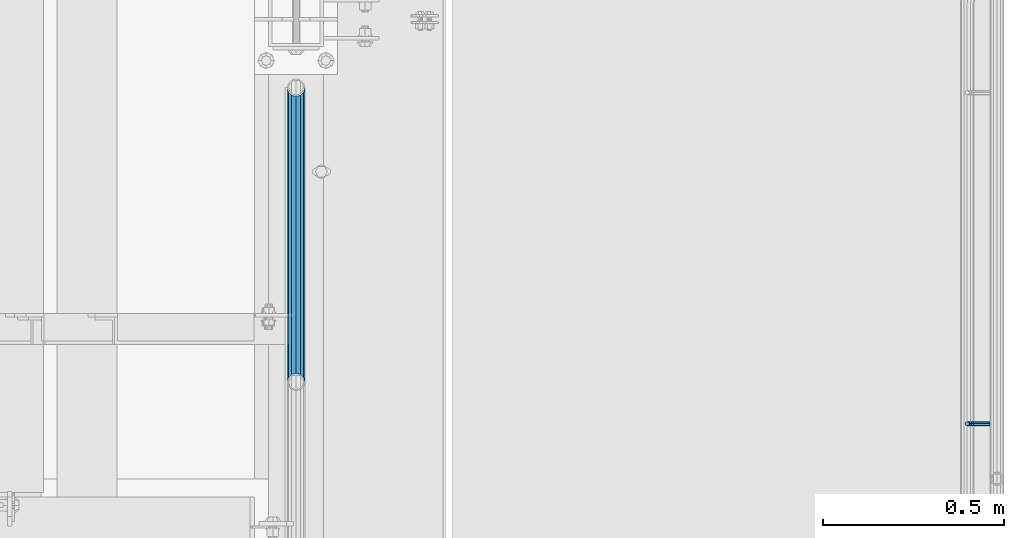
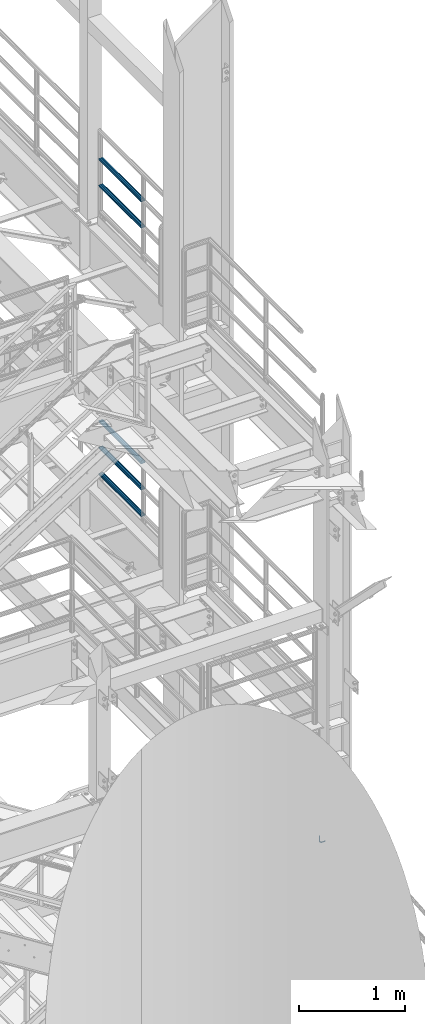
# One storey, part 1223 of 1876: 6 beams, 3 elements without a shape of their own.
"""IFC2X3 building model written with IfcOpenShell, lengths in millimetres."""

from ifc_helpers import new_model, si_unit, frame, origin_with_axes, place, context, subcontext, project, spatial, faceted_brep, material, type_object, element, aggregate, save


model = new_model("IFC2X3")

# Units and contexts
model_context = context("Model", 3, precision=1e-05, world=origin_with_axes())
body_context = subcontext(model_context, "Body", "Model", "MODEL_VIEW")
ifc_project = project(units=[si_unit("LENGTHUNIT", "METRE", prefix="MILLI"), si_unit("AREAUNIT", "SQUARE_METRE"), si_unit("VOLUMEUNIT", "CUBIC_METRE"), si_unit("MASSUNIT", "GRAM", prefix="KILO"), si_unit("TIMEUNIT", "SECOND"), si_unit("PLANEANGLEUNIT", "RADIAN"), si_unit("SOLIDANGLEUNIT", "STERADIAN"), si_unit("THERMODYNAMICTEMPERATUREUNIT", "DEGREE_CELSIUS"), si_unit("LUMINOUSINTENSITYUNIT", "LUMEN")], contexts=[model_context])

# Site, building, storey
site_placement = place(None, origin_with_axes())
site = spatial("IfcSite", under=ifc_project, at=site_placement, CompositionType="ELEMENT")
building_placement = place(site_placement, origin_with_axes())
building = spatial("IfcBuilding", under=site, at=building_placement, Name="Undefined", CompositionType="ELEMENT")
storey_placement = place(building_placement, origin_with_axes())
storey = spatial("IfcBuildingStorey", under=building, at=storey_placement, Name="Undefined", CompositionType="ELEMENT", Elevation=0.0)

# Assembly, beams
assembly_1_placement = place(storey_placement, origin_with_axes())
assembly_1 = element("IfcElementAssembly", 1, at=assembly_1_placement, inside=storey, Name="RAIL", AssemblyPlace="NOTDEFINED", PredefinedType="RIGID_FRAME")
ifc_material_1 = material()
beam_type_1 = type_object("IfcBeamType", Name="PIPE1-1/2SCH40", PredefinedType="NOTDEFINED")
beam_1_placement = place(assembly_1_placement, frame((7620.0, -3542.7031, 8620.125), z_axis=(0.0, 0.0, -1.0), x_axis=(0.0, 1.0, 0.0)))
beam_1 = element("IfcBeam", 2, at=beam_1_placement, type_object=beam_type_1, material=ifc_material_1, Name="RAIL", ObjectType="PIPE1-1/2SCH40", context=body_context, shape_type="Brep", body=[
    faceted_brep([(0.0, 24.1299999999992, 0.0), (12.0650000000064, 20.8971929933177, -12.0649999999987), (12.0650000000064, 20.8971929933177, 12.0649999999987), (12.0650000000064, -20.8971929933177, 12.0649999999987), (12.0650000000064, -20.8971929933177, -12.0649999999987), (0.0, -24.1299999999992, 0.0), (20.8971929933249, -12.0650000000005, 20.8971929933177), (20.8971929933249, -12.0650000000005, 15.8661214311796), (15.2545715621445, -17.7076214311801, 10.2235000000001), (12.5151929933249, -20.4470000000001, 0.0), (15.2545715621445, -17.7076214311801, -10.2235000000001), (20.8971929933249, -12.0650000000005, -15.8661214311796), (20.8971929933249, -12.0650000000005, -20.8971929933177), (24.1300000000063, 0.0, -20.4470000000001), (24.1300000000063, 0.0, -24.130000000001), (21.3906214311868, -10.2235000000001, -17.7076214311819), (21.3906214311868, 10.2235000000001, -17.7076214311819), (20.8971929933249, 12.0650000000005, -15.8661214311796), (20.8971929933249, 12.0650000000005, -20.8971929933177), (15.2545715621445, 17.7076214311801, -10.2235000000001), (12.5151929933249, 20.4470000000001, 0.0), (15.2545715621445, 17.7076214311801, 10.2235000000001), (20.8971929933249, 12.0650000000005, 15.8661214311796), (20.8971929933249, 12.0650000000005, 20.8971929933177), (21.3906214311868, 10.2235000000001, 17.7076214311819), (24.1300000000064, 0.0, 20.4470000000001), (24.1300000000064, 0.0, 24.130000000001), (21.3906214311868, -10.2235000000001, 17.7076214311819), (813.396900000002, 24.1300000000001, 0.0), (801.331900000001, 20.8971929933186, -12.0649999999987), (792.499707006684, 12.0649999999996, -20.8971929933177), (813.396900000002, -24.1300000000319, 0.0), (801.331900000001, -20.8971929933186, -12.0649999999987), (801.331900000001, -20.8971929933186, 12.0649999999987), (792.499707006684, -12.0649999999996, 20.8971929933177), (792.499707006684, -12.0649999999996, -20.8971929933177), (789.266900000001, 0.0, -24.130000000001), (792.00627856883, 10.2235000000001, -17.7076214311819), (789.266900000001, 0.0, -20.4470000000001), (792.499707006684, 12.0649999999678, -15.8661214312124), (792.499707006684, -12.0650000000314, -15.8661214311469), (792.006278568813, -10.2235000000001, -17.7076214311819), (798.142328437831, -17.7076214311801, -10.2235000000001), (800.881707006651, -20.4470000000001, 0.0), (798.142328437831, -17.7076214311801, 10.2235000000001), (792.499707006684, -12.0650000000314, 15.8661214311469), (792.006278568813, -10.2235000000001, 17.7076214311819), (789.266900000001, -9.09494701772928e-13, 20.4470000000001), (789.266900000001, -9.09494701772928e-13, 24.130000000001), (792.499707006684, 12.0649999999996, 20.8971929933177), (801.331900000001, 20.8971929933186, 12.0649999999987), (792.499707006684, 12.0649999999678, 15.8661214312124), (798.142328437896, 17.7076214311801, 10.2235000000001), (800.881707006714, 20.4470000000001, 0.0), (798.142328437896, 17.7076214311801, -10.2235000000001), (792.00627856883, 10.2235000000001, 17.7076214311819)], [[[0, 1, 2]], [[3, 4, 5]], [[6, 7, 8, 9, 10, 11, 12, 4, 3]], [[13, 14, 12, 11, 15]], [[16, 17, 18, 14, 13]], [[2, 1, 18, 17, 19, 20, 21, 22, 23]], [[23, 22, 24, 25, 26]], [[26, 25, 27, 7, 6]], [[1, 0, 28, 29]], [[18, 1, 29, 30]], [[31, 32, 33]], [[6, 3, 33, 34]], [[3, 5, 31, 33]], [[5, 4, 32, 31]], [[4, 12, 35, 32]], [[12, 14, 36, 35]], [[14, 18, 30, 36]], [[37, 38, 36, 30, 39]], [[40, 35, 36, 38, 41]], [[33, 32, 35, 40, 42, 43, 44, 45, 34]], [[34, 45, 46, 47, 48]], [[26, 6, 34, 48]], [[2, 23, 49, 50]], [[23, 26, 48, 49]], [[0, 2, 50, 28]], [[28, 50, 29]], [[49, 51, 52, 53, 54, 39, 30, 29, 50]], [[48, 47, 55, 51, 49]], [[25, 24, 55, 47]], [[55, 24, 22, 21, 52, 51]], [[21, 20, 53, 52]], [[20, 19, 54, 53]], [[19, 17, 16, 37, 39, 54]], [[16, 13, 38, 37]], [[13, 15, 41, 38]], [[41, 15, 11, 10, 42, 40]], [[10, 9, 43, 42]], [[9, 8, 44, 43]], [[8, 7, 27, 46, 45, 44]], [[27, 25, 47, 46]]]),
])
beam_2_placement = place(assembly_1_placement, frame((7620.0, -3542.7031, 8924.925), z_axis=(0.0, 0.0, -1.0), x_axis=(0.0, 1.0, 0.0)))
beam_2 = element("IfcBeam", 3, at=beam_2_placement, type_object=beam_type_1, material=ifc_material_1, Name="RAIL", ObjectType="PIPE1-1/2SCH40", context=body_context, shape_type="Brep", body=[
    faceted_brep([(0.0, 24.1299999999992, 0.0), (12.0650000000064, 20.8971929933177, -12.0649999999987), (12.0650000000064, 20.8971929933177, 12.0649999999987), (12.0650000000064, -20.8971929933177, 12.0649999999987), (12.0650000000064, -20.8971929933177, -12.0649999999987), (0.0, -24.1299999999992, 0.0), (20.8971929933249, -12.0650000000005, 20.8971929933177), (20.8971929933249, -12.0650000000005, 15.8661214311796), (15.2545715621445, -17.7076214311801, 10.2235000000001), (12.5151929933249, -20.4470000000001, 0.0), (15.2545715621445, -17.7076214311801, -10.2235000000001), (20.8971929933249, -12.0650000000005, -15.8661214311796), (20.8971929933249, -12.0650000000005, -20.8971929933177), (24.1300000000063, 0.0, -20.4470000000001), (24.1300000000063, 0.0, -24.130000000001), (21.3906214311868, -10.2235000000001, -17.7076214311819), (21.3906214311868, 10.2235000000001, -17.7076214311819), (20.8971929933249, 12.0650000000005, -15.8661214311796), (20.8971929933249, 12.0650000000005, -20.8971929933177), (15.2545715621445, 17.7076214311801, -10.2235000000001), (12.5151929933249, 20.4470000000001, 0.0), (15.2545715621445, 17.7076214311801, 10.2235000000001), (20.8971929933249, 12.0650000000005, 15.8661214311796), (20.8971929933249, 12.0650000000005, 20.8971929933177), (21.3906214311868, 10.2235000000001, 17.7076214311819), (24.1300000000064, 0.0, 20.4470000000001), (24.1300000000064, 0.0, 24.130000000001), (21.3906214311868, -10.2235000000001, 17.7076214311819), (813.396900000002, 24.1300000000001, 0.0), (801.331900000001, 20.8971929933186, -12.0649999999987), (792.499707006684, 12.0649999999996, -20.8971929933177), (813.396900000002, -24.1300000000319, 0.0), (801.331900000001, -20.8971929933186, -12.0649999999987), (801.331900000001, -20.8971929933186, 12.0649999999987), (792.499707006684, -12.0649999999996, 20.8971929933177), (792.499707006684, -12.0649999999996, -20.8971929933177), (789.266900000001, 0.0, -24.130000000001), (792.00627856883, 10.2235000000001, -17.7076214311819), (789.266900000001, 0.0, -20.4470000000001), (792.499707006684, 12.0649999999678, -15.8661214312124), (792.499707006684, -12.0650000000314, -15.8661214311469), (792.006278568813, -10.2235000000001, -17.7076214311819), (798.142328437831, -17.7076214311801, -10.2235000000001), (800.881707006651, -20.4470000000001, 0.0), (798.142328437831, -17.7076214311801, 10.2235000000001), (792.499707006684, -12.0650000000314, 15.8661214311469), (792.006278568813, -10.2235000000001, 17.7076214311819), (789.266900000001, -9.09494701772928e-13, 20.4470000000001), (789.266900000001, -9.09494701772928e-13, 24.130000000001), (792.499707006684, 12.0649999999996, 20.8971929933177), (801.331900000001, 20.8971929933186, 12.0649999999987), (792.499707006684, 12.0649999999678, 15.8661214312124), (798.142328437896, 17.7076214311801, 10.2235000000001), (800.881707006714, 20.4470000000001, 0.0), (798.142328437896, 17.7076214311801, -10.2235000000001), (792.00627856883, 10.2235000000001, 17.7076214311819)], [[[0, 1, 2]], [[3, 4, 5]], [[6, 7, 8, 9, 10, 11, 12, 4, 3]], [[13, 14, 12, 11, 15]], [[16, 17, 18, 14, 13]], [[2, 1, 18, 17, 19, 20, 21, 22, 23]], [[23, 22, 24, 25, 26]], [[26, 25, 27, 7, 6]], [[1, 0, 28, 29]], [[18, 1, 29, 30]], [[31, 32, 33]], [[6, 3, 33, 34]], [[3, 5, 31, 33]], [[5, 4, 32, 31]], [[4, 12, 35, 32]], [[12, 14, 36, 35]], [[14, 18, 30, 36]], [[37, 38, 36, 30, 39]], [[40, 35, 36, 38, 41]], [[33, 32, 35, 40, 42, 43, 44, 45, 34]], [[34, 45, 46, 47, 48]], [[26, 6, 34, 48]], [[2, 23, 49, 50]], [[23, 26, 48, 49]], [[0, 2, 50, 28]], [[28, 50, 29]], [[49, 51, 52, 53, 54, 39, 30, 29, 50]], [[48, 47, 55, 51, 49]], [[25, 24, 55, 47]], [[55, 24, 22, 21, 52, 51]], [[21, 20, 53, 52]], [[20, 19, 54, 53]], [[19, 17, 16, 37, 39, 54]], [[16, 13, 38, 37]], [[13, 15, 41, 38]], [[41, 15, 11, 10, 42, 40]], [[10, 9, 43, 42]], [[9, 8, 44, 43]], [[8, 7, 27, 46, 45, 44]], [[27, 25, 47, 46]]]),
])
aggregate(assembly_1, [beam_1, beam_2])

assembly_2_placement = place(storey_placement, origin_with_axes())
assembly_2 = element("IfcElementAssembly", 4, at=assembly_2_placement, inside=storey, Name="RAIL", AssemblyPlace="NOTDEFINED", PredefinedType="RIGID_FRAME")
beam_3_placement = place(assembly_2_placement, frame((7620.00000000001, -2729.3062, 5292.725), z_axis=(0.0, 0.0, 1.0), x_axis=(0.0, -1.0, 0.0)))
beam_3 = element("IfcBeam", 5, at=beam_3_placement, type_object=beam_type_1, material=ifc_material_1, Name="RAIL", ObjectType="PIPE1-1/2SCH40", context=body_context, shape_type="Brep", body=[
    faceted_brep([(792.499707006684, -12.0649999999996, 20.8971929933177), (792.499707006684, -12.0650000000314, 15.8661214311469), (792.006278568813, -10.2235000000001, 17.7076214311819), (789.266900000001, -9.09494701772928e-13, 20.4470000000001), (789.266900000001, -9.09494701772928e-13, 24.130000000001), (792.00627856883, 10.2235000000001, 17.7076214311819), (792.499707006684, 12.0649999999678, 15.8661214312124), (792.499707006684, 12.0649999999996, 20.8971929933177), (813.396900000002, 24.1300000000001, 0.0), (801.331900000001, 20.8971929933186, 12.0649999999987), (801.331900000001, 20.8971929933186, -12.0649999999987), (798.142328437896, 17.7076214311801, 10.2235000000001), (800.881707006714, 20.4470000000001, 0.0), (798.142328437896, 17.7076214311801, -10.2235000000001), (792.499707006684, 12.0649999999678, -15.8661214312124), (792.499707006684, 12.0649999999996, -20.8971929933177), (792.00627856883, 10.2235000000001, -17.7076214311819), (789.266900000001, 0.0, -20.4470000000001), (789.266900000001, 0.0, -24.130000000001), (792.499707006684, -12.0650000000314, -15.8661214311469), (792.499707006684, -12.0649999999996, -20.8971929933177), (792.006278568813, -10.2235000000001, -17.7076214311819), (813.396900000002, -24.1300000000319, 0.0), (801.331900000001, -20.8971929933186, -12.0649999999987), (801.331900000001, -20.8971929933186, 12.0649999999987), (798.142328437831, -17.7076214311801, -10.2235000000001), (800.881707006651, -20.4470000000001, 0.0), (798.142328437831, -17.7076214311801, 10.2235000000001), (12.0650000000064, -20.8971929933177, -12.0649999999987), (20.8971929933249, -12.0650000000005, -20.8971929933177), (0.0, 24.1299999999992, 0.0), (12.0650000000064, 20.8971929933177, -12.0649999999987), (12.0650000000064, 20.8971929933177, 12.0649999999987), (20.8971929933249, 12.0650000000005, 20.8971929933177), (24.1300000000064, 0.0, 24.130000000001), (20.8971929933249, 12.0650000000005, -20.8971929933177), (24.1300000000063, 0.0, -24.130000000001), (24.1300000000063, 0.0, -20.4470000000001), (20.8971929933249, -12.0650000000005, -15.8661214311796), (21.3906214311868, -10.2235000000001, -17.7076214311819), (21.3906214311868, 10.2235000000001, -17.7076214311819), (20.8971929933249, 12.0650000000005, -15.8661214311796), (15.2545715621445, 17.7076214311801, -10.2235000000001), (12.5151929933249, 20.4470000000001, 0.0), (15.2545715621445, 17.7076214311801, 10.2235000000001), (20.8971929933249, 12.0650000000005, 15.8661214311796), (21.3906214311868, 10.2235000000001, 17.7076214311819), (24.1300000000064, 0.0, 20.4470000000001), (21.3906214311868, -10.2235000000001, 17.7076214311819), (20.8971929933249, -12.0650000000005, 15.8661214311796), (20.8971929933249, -12.0650000000005, 20.8971929933177), (12.0650000000064, -20.8971929933177, 12.0649999999987), (0.0, -24.1299999999992, 0.0), (15.2545715621445, -17.7076214311801, 10.2235000000001), (12.5151929933249, -20.4470000000001, 0.0), (15.2545715621445, -17.7076214311801, -10.2235000000001)], [[[0, 1, 2, 3, 4]], [[4, 3, 5, 6, 7]], [[8, 9, 10]], [[7, 6, 11, 12, 13, 14, 15, 10, 9]], [[16, 17, 18, 15, 14]], [[19, 20, 18, 17, 21]], [[22, 23, 24]], [[24, 23, 20, 19, 25, 26, 27, 1, 0]], [[28, 29, 20, 23]], [[30, 31, 32]], [[33, 34, 4, 7]], [[32, 33, 7, 9]], [[30, 32, 9, 8]], [[31, 30, 8, 10]], [[35, 31, 10, 15]], [[36, 35, 15, 18]], [[29, 36, 18, 20]], [[37, 36, 29, 38, 39]], [[40, 41, 35, 36, 37]], [[32, 31, 35, 41, 42, 43, 44, 45, 33]], [[33, 45, 46, 47, 34]], [[34, 47, 48, 49, 50]], [[34, 50, 0, 4]], [[50, 51, 24, 0]], [[51, 52, 22, 24]], [[52, 28, 23, 22]], [[51, 28, 52]], [[50, 49, 53, 54, 55, 38, 29, 28, 51]], [[55, 54, 26, 25]], [[21, 39, 38, 55, 25, 19]], [[37, 39, 21, 17]], [[40, 37, 17, 16]], [[42, 41, 40, 16, 14, 13]], [[43, 42, 13, 12]], [[44, 43, 12, 11]], [[5, 46, 45, 44, 11, 6]], [[47, 46, 5, 3]], [[48, 47, 3, 2]], [[53, 49, 48, 2, 1, 27]], [[54, 53, 27, 26]]]),
])
beam_4_placement = place(assembly_2_placement, frame((7620.0, -3542.70310000001, 5597.525), z_axis=(0.0, 0.0, -1.0), x_axis=(0.0, 1.0, 0.0)))
beam_4 = element("IfcBeam", 6, at=beam_4_placement, type_object=beam_type_1, material=ifc_material_1, Name="RAIL", ObjectType="PIPE1-1/2SCH40", context=body_context, shape_type="Brep", body=[
    faceted_brep([(0.0, 24.1299999999992, 0.0), (12.0650000000064, 20.8971929933177, -12.0649999999987), (12.0650000000064, 20.8971929933177, 12.0649999999987), (12.0650000000064, -20.8971929933177, 12.0649999999987), (12.0650000000064, -20.8971929933177, -12.0649999999987), (0.0, -24.1299999999992, 0.0), (20.8971929933249, -12.0650000000005, 20.8971929933177), (20.8971929933249, -12.0650000000005, 15.8661214311796), (15.2545715621445, -17.7076214311801, 10.2235000000001), (12.5151929933249, -20.4470000000001, 0.0), (15.2545715621445, -17.7076214311801, -10.2235000000001), (20.8971929933249, -12.0650000000005, -15.8661214311796), (20.8971929933249, -12.0650000000005, -20.8971929933177), (24.1300000000063, 0.0, -20.4470000000001), (24.1300000000063, 0.0, -24.130000000001), (21.3906214311868, -10.2235000000001, -17.7076214311819), (21.3906214311868, 10.2235000000001, -17.7076214311819), (20.8971929933249, 12.0650000000005, -15.8661214311796), (20.8971929933249, 12.0650000000005, -20.8971929933177), (15.2545715621445, 17.7076214311801, -10.2235000000001), (12.5151929933249, 20.4470000000001, 0.0), (15.2545715621445, 17.7076214311801, 10.2235000000001), (20.8971929933249, 12.0650000000005, 15.8661214311796), (20.8971929933249, 12.0650000000005, 20.8971929933177), (21.3906214311868, 10.2235000000001, 17.7076214311819), (24.1300000000064, 0.0, 20.4470000000001), (24.1300000000064, 0.0, 24.130000000001), (21.3906214311868, -10.2235000000001, 17.7076214311819), (813.396900000002, 24.1300000000001, 0.0), (801.331900000001, 20.8971929933186, -12.0649999999987), (792.499707006684, 12.0649999999996, -20.8971929933177), (813.396900000002, -24.1300000000319, 0.0), (801.331900000001, -20.8971929933186, -12.0649999999987), (801.331900000001, -20.8971929933186, 12.0649999999987), (792.499707006684, -12.0649999999996, 20.8971929933177), (792.499707006684, -12.0649999999996, -20.8971929933177), (789.266900000001, 0.0, -24.130000000001), (792.00627856883, 10.2235000000001, -17.7076214311819), (789.266900000001, 0.0, -20.4470000000001), (792.499707006684, 12.0649999999678, -15.8661214312124), (792.499707006684, -12.0650000000314, -15.8661214311469), (792.006278568813, -10.2235000000001, -17.7076214311819), (798.142328437831, -17.7076214311801, -10.2235000000001), (800.881707006651, -20.4470000000001, 0.0), (798.142328437831, -17.7076214311801, 10.2235000000001), (792.499707006684, -12.0650000000314, 15.8661214311469), (792.006278568813, -10.2235000000001, 17.7076214311819), (789.266900000001, -9.09494701772928e-13, 20.4470000000001), (789.266900000001, -9.09494701772928e-13, 24.130000000001), (792.499707006684, 12.0649999999996, 20.8971929933177), (801.331900000001, 20.8971929933186, 12.0649999999987), (792.499707006684, 12.0649999999678, 15.8661214312124), (798.142328437896, 17.7076214311801, 10.2235000000001), (800.881707006714, 20.4470000000001, 0.0), (798.142328437896, 17.7076214311801, -10.2235000000001), (792.00627856883, 10.2235000000001, 17.7076214311819)], [[[0, 1, 2]], [[3, 4, 5]], [[6, 7, 8, 9, 10, 11, 12, 4, 3]], [[13, 14, 12, 11, 15]], [[16, 17, 18, 14, 13]], [[2, 1, 18, 17, 19, 20, 21, 22, 23]], [[23, 22, 24, 25, 26]], [[26, 25, 27, 7, 6]], [[1, 0, 28, 29]], [[18, 1, 29, 30]], [[31, 32, 33]], [[6, 3, 33, 34]], [[3, 5, 31, 33]], [[5, 4, 32, 31]], [[4, 12, 35, 32]], [[12, 14, 36, 35]], [[14, 18, 30, 36]], [[37, 38, 36, 30, 39]], [[40, 35, 36, 38, 41]], [[33, 32, 35, 40, 42, 43, 44, 45, 34]], [[34, 45, 46, 47, 48]], [[26, 6, 34, 48]], [[2, 23, 49, 50]], [[23, 26, 48, 49]], [[0, 2, 50, 28]], [[28, 50, 29]], [[49, 51, 52, 53, 54, 39, 30, 29, 50]], [[48, 47, 55, 51, 49]], [[25, 24, 55, 47]], [[55, 24, 22, 21, 52, 51]], [[21, 20, 53, 52]], [[20, 19, 54, 53]], [[19, 17, 16, 37, 39, 54]], [[16, 13, 38, 37]], [[13, 15, 41, 38]], [[41, 15, 11, 10, 42, 40]], [[10, 9, 43, 42]], [[9, 8, 44, 43]], [[8, 7, 27, 46, 45, 44]], [[27, 25, 47, 46]]]),
])
beam_5_placement = place(assembly_2_placement, frame((7620.0, -3542.70310000001, 5902.325), z_axis=(0.0, 0.0, -1.0), x_axis=(0.0, 1.0, 0.0)))
beam_5 = element("IfcBeam", 7, at=beam_5_placement, type_object=beam_type_1, material=ifc_material_1, Name="RAIL", ObjectType="PIPE1-1/2SCH40", context=body_context, shape_type="Brep", body=[
    faceted_brep([(0.0, 24.1299999999992, 0.0), (12.0650000000064, 20.8971929933177, -12.0649999999987), (12.0650000000064, 20.8971929933177, 12.0649999999987), (12.0650000000064, -20.8971929933177, 12.0649999999987), (12.0650000000064, -20.8971929933177, -12.0649999999987), (0.0, -24.1299999999992, 0.0), (20.8971929933249, -12.0650000000005, 20.8971929933177), (20.8971929933249, -12.0650000000005, 15.8661214311796), (15.2545715621445, -17.7076214311801, 10.2235000000001), (12.5151929933249, -20.4470000000001, 0.0), (15.2545715621445, -17.7076214311801, -10.2235000000001), (20.8971929933249, -12.0650000000005, -15.8661214311796), (20.8971929933249, -12.0650000000005, -20.8971929933177), (24.1300000000063, 0.0, -20.4470000000001), (24.1300000000063, 0.0, -24.130000000001), (21.3906214311868, -10.2235000000001, -17.7076214311819), (21.3906214311868, 10.2235000000001, -17.7076214311819), (20.8971929933249, 12.0650000000005, -15.8661214311796), (20.8971929933249, 12.0650000000005, -20.8971929933177), (15.2545715621445, 17.7076214311801, -10.2235000000001), (12.5151929933249, 20.4470000000001, 0.0), (15.2545715621445, 17.7076214311801, 10.2235000000001), (20.8971929933249, 12.0650000000005, 15.8661214311796), (20.8971929933249, 12.0650000000005, 20.8971929933177), (21.3906214311868, 10.2235000000001, 17.7076214311819), (24.1300000000064, 0.0, 20.4470000000001), (24.1300000000064, 0.0, 24.130000000001), (21.3906214311868, -10.2235000000001, 17.7076214311819), (813.396900000002, 24.1300000000001, 0.0), (801.331900000001, 20.8971929933186, -12.0649999999987), (792.499707006684, 12.0649999999996, -20.8971929933177), (813.396900000002, -24.1300000000319, 0.0), (801.331900000001, -20.8971929933186, -12.0649999999987), (801.331900000001, -20.8971929933186, 12.0649999999987), (792.499707006684, -12.0649999999996, 20.8971929933177), (792.499707006684, -12.0649999999996, -20.8971929933177), (789.266900000001, 0.0, -24.130000000001), (792.00627856883, 10.2235000000001, -17.7076214311819), (789.266900000001, 0.0, -20.4470000000001), (792.499707006684, 12.0649999999678, -15.8661214312124), (792.499707006684, -12.0650000000314, -15.8661214311469), (792.006278568813, -10.2235000000001, -17.7076214311819), (798.142328437831, -17.7076214311801, -10.2235000000001), (800.881707006651, -20.4470000000001, 0.0), (798.142328437831, -17.7076214311801, 10.2235000000001), (792.499707006684, -12.0650000000314, 15.8661214311469), (792.006278568813, -10.2235000000001, 17.7076214311819), (789.266900000001, -9.09494701772928e-13, 20.4470000000001), (789.266900000001, -9.09494701772928e-13, 24.130000000001), (792.499707006684, 12.0649999999996, 20.8971929933177), (801.331900000001, 20.8971929933186, 12.0649999999987), (792.499707006684, 12.0649999999678, 15.8661214312124), (798.142328437896, 17.7076214311801, 10.2235000000001), (800.881707006714, 20.4470000000001, 0.0), (798.142328437896, 17.7076214311801, -10.2235000000001), (792.00627856883, 10.2235000000001, 17.7076214311819)], [[[0, 1, 2]], [[3, 4, 5]], [[6, 7, 8, 9, 10, 11, 12, 4, 3]], [[13, 14, 12, 11, 15]], [[16, 17, 18, 14, 13]], [[2, 1, 18, 17, 19, 20, 21, 22, 23]], [[23, 22, 24, 25, 26]], [[26, 25, 27, 7, 6]], [[1, 0, 28, 29]], [[18, 1, 29, 30]], [[31, 32, 33]], [[6, 3, 33, 34]], [[3, 5, 31, 33]], [[5, 4, 32, 31]], [[4, 12, 35, 32]], [[12, 14, 36, 35]], [[14, 18, 30, 36]], [[37, 38, 36, 30, 39]], [[40, 35, 36, 38, 41]], [[33, 32, 35, 40, 42, 43, 44, 45, 34]], [[34, 45, 46, 47, 48]], [[26, 6, 34, 48]], [[2, 23, 49, 50]], [[23, 26, 48, 49]], [[0, 2, 50, 28]], [[28, 50, 29]], [[49, 51, 52, 53, 54, 39, 30, 29, 50]], [[48, 47, 55, 51, 49]], [[25, 24, 55, 47]], [[55, 24, 22, 21, 52, 51]], [[21, 20, 53, 52]], [[20, 19, 54, 53]], [[19, 17, 16, 37, 39, 54]], [[16, 13, 38, 37]], [[13, 15, 41, 38]], [[41, 15, 11, 10, 42, 40]], [[10, 9, 43, 42]], [[9, 8, 44, 43]], [[8, 7, 27, 46, 45, 44]], [[27, 25, 47, 46]]]),
])
aggregate(assembly_2, [beam_3, beam_4, beam_5])

# Assembly, beam
assembly_3_placement = place(storey_placement, origin_with_axes())
assembly_3 = element("IfcElementAssembly", 8, at=assembly_3_placement, inside=storey, Name="RAIL", AssemblyPlace="NOTDEFINED", PredefinedType="RIGID_FRAME")
ifc_material_2 = material(Name="STEEL/A36")
beam_type_2 = type_object("IfcBeamType", PredefinedType="NOTDEFINED")
beam_6_placement = place(assembly_3_placement, frame((9537.7001953125, -3657.60009321068, 939.800003052647), z_axis=(0.0, 1.0, 0.0), x_axis=(-1.0, 0.0, 0.0)))
beam_6 = element("IfcBeam", 9, at=beam_6_placement, type_object=beam_type_2, material=ifc_material_2, Name="BRACKET", context=body_context, shape_type="Brep", body=[
    faceted_brep([(0.0, -6.35000000000036, 0.0), (0.0, -4.49012806053463, -4.49012806053452), (38.1000003814697, -4.49012806053463, -4.49012806053452), (38.1000003814697, -6.35000000000002, 0.0), (0.0, 0.0, -6.34999999999991), (38.1000003814697, 0.0, -6.34999999999991), (0.0, 4.49012806053463, -4.49012806053452), (38.1000003814697, 4.49012806053463, -4.49012806053452), (0.0, 6.35000000000036, 0.0), (38.1000003814697, 6.35000000000002, 0.0), (0.0, 4.49012806053463, 4.49012806053452), (38.1000003814697, 4.49012806053463, 4.49012806053452), (0.0, 0.0, 6.34999999999991), (38.1000003814697, 0.0, 6.34999999999991), (0.0, -4.49012806053463, 4.49012806053452), (38.1000003814697, -4.49012806053463, 4.49012806053452), (50.2501992130801, -3.93317518627066, 0.0), (49.5384570355254, -2.21487756830652, 4.49012806053452), (47.8201594175607, 1.93345984517589, 6.34999999999991), (46.1018617995978, 6.08179725865841, 4.49012806053452), (45.3901196220431, 7.80009487662255, 0.0), (46.1018617995978, 6.08179725865841, -4.49012806053452), (47.8201594175607, 1.93345984517589, -6.34999999999991), (49.5384570355254, -2.21487756830652, -4.49012806053452), (59.2355123538691, 4.26448764613235, -4.49012806053452), (60.5506404144035, 2.9493595855979, 0.0), (56.060512353868, 7.43948764613231, -6.34999999999991), (52.8855123538688, 10.6144876461323, -4.49012806053452), (51.5703842933344, 11.9296157066667, 0.0), (52.8855123538688, 10.6144876461323, 4.49012806053452), (56.060512353868, 7.43948764613231, 6.34999999999991), (59.2355123538691, 4.26448764613235, 4.49012806053452), (65.7148775683072, 13.9615429644757, -4.49012806053452), (67.4331751862719, 13.2498007869216, 0.0), (61.5665401548249, 15.6798405824397, -6.34999999999991), (57.4182027413426, 17.3981382004039, -4.49012806053452), (55.6999051233779, 18.1098803779579, 0.0), (57.4182027413426, 17.3981382004039, 4.49012806053452), (61.5665401548249, 15.6798405824397, 6.34999999999991), (65.7148775683072, 13.9615429644757, 4.49012806053452), (67.9901280605336, 25.3999996185304, -4.49012806053452), (69.8500000000004, 25.3999996185303, 0.0), (63.5, 25.3999996185303, -6.34999999999991), (59.0098719394646, 25.3999996185303, -4.49012806053452), (57.1499999999996, 25.3999996185303, 0.0), (59.0098719394646, 25.3999996185303, 4.49012806053452), (63.5, 25.3999996185303, 6.34999999999991), (67.9901280605336, 25.3999996185304, 4.49012806053452), (67.9901280605354, 82.5500030517578, -4.49012806053452), (69.8500000000004, 82.5500030517578, 0.0), (63.5, 82.5500030517578, -6.34999999999991), (59.0098719394646, 82.5500030517578, -4.49012806053452), (57.1499999999996, 82.5500030517578, 0.0), (59.0098719394646, 82.5500030517578, 4.49012806053452), (63.5, 82.5500030517578, 6.34999999999991), (67.9901280605354, 82.5500030517578, 4.49012806053452)], [[[0, 1, 2, 3]], [[1, 4, 5, 2]], [[4, 6, 7, 5]], [[6, 8, 9, 7]], [[8, 10, 11, 9]], [[10, 12, 13, 11]], [[12, 14, 15, 13]], [[14, 0, 3, 15]], [[14, 12, 10, 8, 6, 4, 1, 0]], [[15, 3, 16, 17]], [[13, 15, 17, 18]], [[11, 13, 18, 19]], [[9, 11, 19, 20]], [[7, 9, 20, 21]], [[5, 7, 21, 22]], [[2, 5, 22, 23]], [[3, 2, 23, 16]], [[23, 24, 25, 16]], [[22, 26, 24, 23]], [[21, 27, 26, 22]], [[20, 28, 27, 21]], [[19, 29, 28, 20]], [[18, 30, 29, 19]], [[17, 31, 30, 18]], [[16, 25, 31, 17]], [[24, 32, 33, 25]], [[26, 34, 32, 24]], [[27, 35, 34, 26]], [[28, 36, 35, 27]], [[29, 37, 36, 28]], [[30, 38, 37, 29]], [[31, 39, 38, 30]], [[25, 33, 39, 31]], [[32, 40, 41, 33]], [[34, 42, 40, 32]], [[35, 43, 42, 34]], [[36, 44, 43, 35]], [[37, 45, 44, 36]], [[38, 46, 45, 37]], [[39, 47, 46, 38]], [[33, 41, 47, 39]], [[41, 40, 48, 49]], [[40, 42, 50, 48]], [[42, 43, 51, 50]], [[43, 44, 52, 51]], [[44, 45, 53, 52]], [[45, 46, 54, 53]], [[46, 47, 55, 54]], [[47, 41, 49, 55]], [[50, 51, 52, 53, 54, 55, 49, 48]]]),
])
aggregate(assembly_3, [beam_6])

save(model, "model.ifc")
